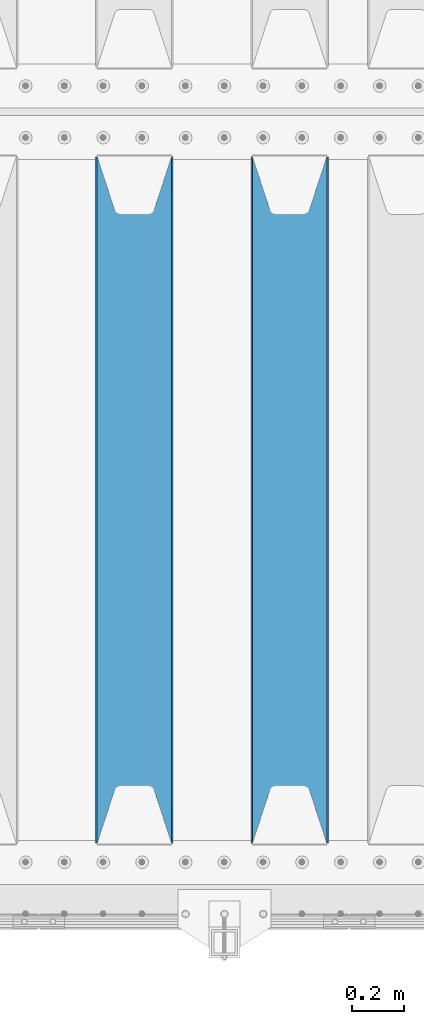
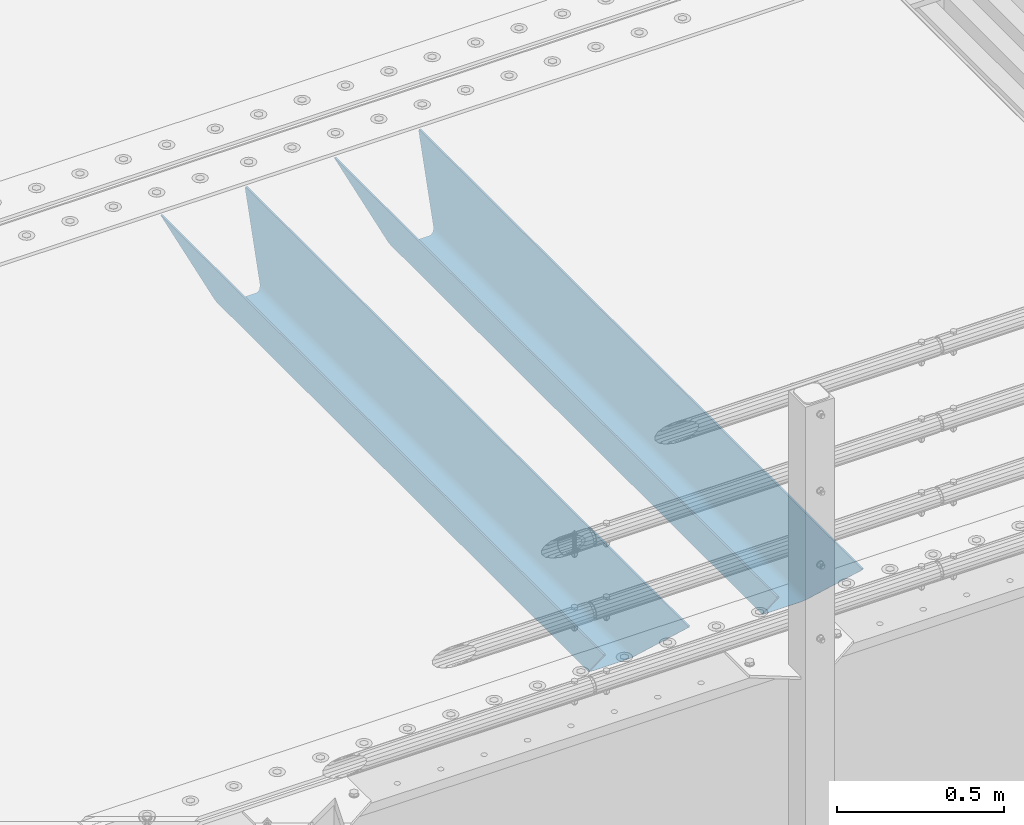
# One storey, part 130 of 242: 2 beams.
"""IFC2X3 building model written with IfcOpenShell, lengths in millimetres."""

from ifc_helpers import new_model, si_unit, frame, origin_with_axes, place, context, subcontext, project, spatial, faceted_brep, material, type_object, element, save


model = new_model("IFC2X3")

# Units and contexts
model_context = context("Model", 3, precision=1e-05, world=origin_with_axes())
body_context = subcontext(model_context, "Body", "Model", "MODEL_VIEW")
ifc_project = project(units=[si_unit("LENGTHUNIT", "METRE", prefix="MILLI"), si_unit("AREAUNIT", "SQUARE_METRE"), si_unit("VOLUMEUNIT", "CUBIC_METRE"), si_unit("MASSUNIT", "GRAM", prefix="KILO"), si_unit("TIMEUNIT", "SECOND"), si_unit("PLANEANGLEUNIT", "RADIAN"), si_unit("SOLIDANGLEUNIT", "STERADIAN"), si_unit("THERMODYNAMICTEMPERATUREUNIT", "DEGREE_CELSIUS"), si_unit("LUMINOUSINTENSITYUNIT", "LUMEN")], contexts=[model_context])

# Site, building, storey
site_placement = place(None, origin_with_axes())
site = spatial("IfcSite", under=ifc_project, at=site_placement, CompositionType="ELEMENT")
building_placement = place(site_placement, origin_with_axes())
building = spatial("IfcBuilding", under=site, at=building_placement, Name="Standard", CompositionType="ELEMENT")
storey_placement = place(building_placement, origin_with_axes())
storey = spatial("IfcBuildingStorey", under=building, at=storey_placement, Name="Undefined", CompositionType="ELEMENT", Elevation=0.0)

# Beams
ifc_material = material(Name="STEEL/S355N")
beam_type = type_object("IfcBeamType", PredefinedType="NOTDEFINED")
beam_1_placement = place(storey_placement, frame((-23780.0, -23825.0, -115.0), z_axis=(0.0, 0.0, 1.0), x_axis=(0.0, 1.0, 0.0)))
element("IfcBeam", 1, at=beam_1_placement, inside=storey, type_object=beam_type, material=ifc_material, context=body_context, shape_type="Brep", body=[
    faceted_brep([(0.0, 150.0, 115.0), (0.0, 143.689999999999, 115.0), (2650.00000000297, 143.689999999999, 115.0), (2650.00000000297, 150.0, 115.0), (2650.00000000297, 142.059565218402, 110.000000003099), (2650.00000000297, 148.369565218403, 110.000000003099), (2441.90079219209, -80.1103600731112, -98.0992078077845), (2437.7588105432, -77.5672621345584, -102.241189456673), (2434.06523489747, -74.4080125315522, -105.934765102404), (2430.91086095089, -70.710272125576, -109.089139048974), (2428.37322971128, -66.5649389910068, -111.626770288588), (2426.51472138055, -62.0739139532889, -113.485278619323), (2425.38102192092, -57.3475956567672, -114.618978078955), (2424.99999999987, -52.5021667386536, -115.0), (2424.99999999987, 52.5021667386536, -115.0), (2425.38102192092, 57.3475956567672, -114.618978078955), (2426.51472138055, 62.0739139532889, -113.485278619323), (2428.37322971128, 66.5649389910068, -111.626770288588), (2430.91086095089, 70.710272125576, -109.089139048974), (2434.06523489747, 74.4080125315522, -105.934765102404), (2437.7588105432, 77.5672621345584, -102.241189456673), (2441.90079219209, 80.1103600731112, -98.0992078077846), (2446.38936140511, 81.9747917625791, -93.6106385947584), (2448.2494850041, 76.2713538057251, -91.7505149957729), (2444.62967112262, 74.76777986261, -95.3703288772456), (2441.28936334126, 72.7168944282894, -98.710636658607), (2438.31067330438, 70.1691124903846, -101.689326695487), (2435.76682334747, 67.1870637758839, -104.233176652398), (2433.72034654133, 63.8440531834895, -106.279653458539), (2432.22154950042, 60.222258798236, -107.778450499454), (2431.30727574265, 56.4107117849089, -108.692724257221), (2430.99999999987, 52.5031078186876, -109.0), (2430.99999999987, -52.5031078186876, -109.0), (2431.30727574265, -56.4107117849089, -108.692724257221), (2432.22154950042, -60.222258798236, -107.778450499454), (2433.72034654133, -63.8440531834895, -106.279653458539), (2435.76682334747, -67.1870637758839, -104.233176652398), (2438.31067330438, -70.1691124903846, -101.689326695487), (2441.28936334126, -72.7168944282894, -98.7106366586071), (2444.62967112262, -74.76777986261, -95.3703288772457), (2448.2494850041, -76.2713538057251, -91.7505149957729), (2650.00000000297, -142.059565218402, 110.000000003099), (2650.00000000297, -148.369565218403, 110.000000003099), (2446.38936140511, -81.9747917625791, -93.6106385947584), (2650.00000000297, -143.689999999999, 115.0), (2650.00000000297, -150.0, 115.0), (0.0, -143.689999999999, 115.0), (0.0, -150.0, 115.0), (0.0, -148.369565218261, 110.000000002669), (203.610638597427, -81.9747917625791, -93.6106385947584), (208.099207810454, -80.1103600731112, -98.0992078077845), (212.241189459342, -77.5672621345584, -102.241189456673), (215.934765105074, -74.4080125315522, -105.934765102404), (219.089139051644, -70.710272125576, -109.089139048974), (221.626770291256, -66.5649389910068, -111.626770288588), (223.485278621993, -62.0739139532889, -113.485278619323), (224.618978081624, -57.3475956567672, -114.618978078955), (225.00000000267, -52.5021667386536, -115.0), (225.00000000267, 52.5021667386536, -115.0), (224.618978081624, 57.3475956567672, -114.618978078955), (223.485278621993, 62.0739139532889, -113.485278619323), (221.626770291256, 66.5649389910068, -111.626770288588), (219.089139051644, 70.710272125576, -109.089139048974), (215.934765105074, 74.4080125315522, -105.934765102404), (212.241189459342, 77.5672621345584, -102.241189456673), (208.099207810454, 80.1103600731112, -98.0992078077846), (203.610638597427, 81.9747917625791, -93.6106385947584), (0.0, 148.369565218261, 110.000000002669), (0.0, 142.05956521826, 110.000000002669), (201.750514998443, 76.2713538057251, -91.7505149957729), (205.370328879915, 74.76777986261, -95.3703288772456), (208.710636661275, 72.7168944282894, -98.710636658607), (211.689326698157, 70.1691124903846, -101.689326695487), (214.233176655067, 67.1870637758839, -104.233176652398), (216.279653461206, 63.8440531834895, -106.279653458539), (217.778450502123, 60.222258798236, -107.778450499454), (218.69272425989, 56.4107117849089, -108.692724257221), (219.00000000267, 52.5031078186876, -109.0), (219.00000000267, -52.5031078186876, -109.0), (218.69272425989, -56.4107117849089, -108.692724257221), (217.778450502123, -60.222258798236, -107.778450499454), (216.279653461206, -63.8440531834895, -106.279653458539), (214.233176655067, -67.1870637758839, -104.233176652398), (211.689326698157, -70.1691124903846, -101.689326695487), (208.710636661275, -72.7168944282894, -98.7106366586071), (205.370328879915, -74.76777986261, -95.3703288772457), (201.750514998443, -76.2713538057251, -91.7505149957729), (0.0, -142.05956521826, 110.000000002669)], [[[0, 1, 2, 3]], [[3, 2, 4, 5]], [[6, 7, 8, 9, 10, 11, 12, 13, 14, 15, 16, 17, 18, 19, 20, 21, 22, 5, 4, 23, 24, 25, 26, 27, 28, 29, 30, 31, 32, 33, 34, 35, 36, 37, 38, 39, 40, 41, 42, 43]], [[44, 45, 42, 41]], [[46, 47, 45, 44]], [[43, 42, 45, 47, 48, 49]], [[6, 43, 49, 50]], [[7, 6, 50, 51]], [[8, 7, 51, 52]], [[9, 8, 52, 53]], [[10, 9, 53, 54]], [[11, 10, 54, 55]], [[12, 11, 55, 56]], [[13, 12, 56, 57]], [[14, 13, 57, 58]], [[15, 14, 58, 59]], [[16, 15, 59, 60]], [[17, 16, 60, 61]], [[18, 17, 61, 62]], [[19, 18, 62, 63]], [[20, 19, 63, 64]], [[21, 20, 64, 65]], [[22, 21, 65, 66]], [[0, 3, 5, 22, 66, 67]], [[1, 0, 67, 68]], [[23, 4, 2, 1, 68, 69]], [[24, 23, 69, 70]], [[25, 24, 70, 71]], [[26, 25, 71, 72]], [[27, 26, 72, 73]], [[28, 27, 73, 74]], [[29, 28, 74, 75]], [[30, 29, 75, 76]], [[31, 30, 76, 77]], [[32, 31, 77, 78]], [[33, 32, 78, 79]], [[34, 33, 79, 80]], [[35, 34, 80, 81]], [[36, 35, 81, 82]], [[37, 36, 82, 83]], [[38, 37, 83, 84]], [[39, 38, 84, 85]], [[40, 39, 85, 86]], [[46, 44, 41, 40, 86, 87]], [[47, 46, 87, 48]], [[86, 85, 84, 83, 82, 81, 80, 79, 78, 77, 76, 75, 74, 73, 72, 71, 70, 69, 68, 67, 66, 65, 64, 63, 62, 61, 60, 59, 58, 57, 56, 55, 54, 53, 52, 51, 50, 49, 48, 87]]]),
])
beam_2_placement = place(storey_placement, frame((-24380.0, -23825.0, -115.0), z_axis=(0.0, 0.0, 1.0), x_axis=(0.0, 1.0, 0.0)))
element("IfcBeam", 2, at=beam_2_placement, inside=storey, type_object=beam_type, material=ifc_material, context=body_context, shape_type="Brep", body=[
    faceted_brep([(0.0, 150.0, 115.0), (0.0, 143.689999999999, 115.0), (2650.00000000297, 143.689999999999, 115.0), (2650.00000000297, 150.0, 115.0), (2650.00000000297, 142.059565218402, 110.000000003099), (2650.00000000297, 148.369565218403, 110.000000003099), (2441.90079219209, -80.1103600731112, -98.0992078077845), (2437.7588105432, -77.5672621345584, -102.241189456673), (2434.06523489747, -74.4080125315522, -105.934765102404), (2430.91086095089, -70.710272125576, -109.089139048974), (2428.37322971128, -66.5649389910068, -111.626770288588), (2426.51472138055, -62.0739139532889, -113.485278619323), (2425.38102192092, -57.3475956567672, -114.618978078955), (2424.99999999987, -52.5021667386536, -115.0), (2424.99999999987, 52.5021667386536, -115.0), (2425.38102192092, 57.3475956567672, -114.618978078955), (2426.51472138055, 62.0739139532889, -113.485278619323), (2428.37322971128, 66.5649389910068, -111.626770288588), (2430.91086095089, 70.710272125576, -109.089139048974), (2434.06523489747, 74.4080125315522, -105.934765102404), (2437.7588105432, 77.5672621345584, -102.241189456673), (2441.90079219209, 80.1103600731112, -98.0992078077846), (2446.38936140511, 81.9747917625791, -93.6106385947584), (2448.2494850041, 76.2713538057251, -91.7505149957729), (2444.62967112262, 74.76777986261, -95.3703288772456), (2441.28936334126, 72.7168944282894, -98.710636658607), (2438.31067330438, 70.1691124903846, -101.689326695487), (2435.76682334747, 67.1870637758839, -104.233176652398), (2433.72034654133, 63.8440531834895, -106.279653458539), (2432.22154950042, 60.222258798236, -107.778450499454), (2431.30727574265, 56.4107117849089, -108.692724257221), (2430.99999999987, 52.5031078186876, -109.0), (2430.99999999987, -52.5031078186876, -109.0), (2431.30727574265, -56.4107117849089, -108.692724257221), (2432.22154950042, -60.222258798236, -107.778450499454), (2433.72034654133, -63.8440531834895, -106.279653458539), (2435.76682334747, -67.1870637758839, -104.233176652398), (2438.31067330438, -70.1691124903846, -101.689326695487), (2441.28936334126, -72.7168944282894, -98.7106366586071), (2444.62967112262, -74.76777986261, -95.3703288772457), (2448.2494850041, -76.2713538057251, -91.7505149957729), (2650.00000000297, -142.059565218402, 110.000000003099), (2650.00000000297, -148.369565218403, 110.000000003099), (2446.38936140511, -81.9747917625791, -93.6106385947584), (2650.00000000297, -143.689999999999, 115.0), (2650.00000000297, -150.0, 115.0), (0.0, -143.689999999999, 115.0), (0.0, -150.0, 115.0), (0.0, -148.369565218261, 110.000000002669), (203.610638597427, -81.9747917625791, -93.6106385947584), (208.099207810454, -80.1103600731112, -98.0992078077845), (212.241189459342, -77.5672621345584, -102.241189456673), (215.934765105074, -74.4080125315522, -105.934765102404), (219.089139051644, -70.710272125576, -109.089139048974), (221.626770291256, -66.5649389910068, -111.626770288588), (223.485278621993, -62.0739139532889, -113.485278619323), (224.618978081624, -57.3475956567672, -114.618978078955), (225.00000000267, -52.5021667386536, -115.0), (225.00000000267, 52.5021667386536, -115.0), (224.618978081624, 57.3475956567672, -114.618978078955), (223.485278621993, 62.0739139532889, -113.485278619323), (221.626770291256, 66.5649389910068, -111.626770288588), (219.089139051644, 70.710272125576, -109.089139048974), (215.934765105074, 74.4080125315522, -105.934765102404), (212.241189459342, 77.5672621345584, -102.241189456673), (208.099207810454, 80.1103600731112, -98.0992078077846), (203.610638597427, 81.9747917625791, -93.6106385947584), (0.0, 148.369565218261, 110.000000002669), (0.0, 142.05956521826, 110.000000002669), (201.750514998443, 76.2713538057251, -91.7505149957729), (205.370328879915, 74.76777986261, -95.3703288772456), (208.710636661275, 72.7168944282894, -98.710636658607), (211.689326698157, 70.1691124903846, -101.689326695487), (214.233176655067, 67.1870637758839, -104.233176652398), (216.279653461206, 63.8440531834895, -106.279653458539), (217.778450502123, 60.222258798236, -107.778450499454), (218.69272425989, 56.4107117849089, -108.692724257221), (219.00000000267, 52.5031078186876, -109.0), (219.00000000267, -52.5031078186876, -109.0), (218.69272425989, -56.4107117849089, -108.692724257221), (217.778450502123, -60.222258798236, -107.778450499454), (216.279653461206, -63.8440531834895, -106.279653458539), (214.233176655067, -67.1870637758839, -104.233176652398), (211.689326698157, -70.1691124903846, -101.689326695487), (208.710636661275, -72.7168944282894, -98.7106366586071), (205.370328879915, -74.76777986261, -95.3703288772457), (201.750514998443, -76.2713538057251, -91.7505149957729), (0.0, -142.05956521826, 110.000000002669)], [[[0, 1, 2, 3]], [[3, 2, 4, 5]], [[6, 7, 8, 9, 10, 11, 12, 13, 14, 15, 16, 17, 18, 19, 20, 21, 22, 5, 4, 23, 24, 25, 26, 27, 28, 29, 30, 31, 32, 33, 34, 35, 36, 37, 38, 39, 40, 41, 42, 43]], [[44, 45, 42, 41]], [[46, 47, 45, 44]], [[43, 42, 45, 47, 48, 49]], [[6, 43, 49, 50]], [[7, 6, 50, 51]], [[8, 7, 51, 52]], [[9, 8, 52, 53]], [[10, 9, 53, 54]], [[11, 10, 54, 55]], [[12, 11, 55, 56]], [[13, 12, 56, 57]], [[14, 13, 57, 58]], [[15, 14, 58, 59]], [[16, 15, 59, 60]], [[17, 16, 60, 61]], [[18, 17, 61, 62]], [[19, 18, 62, 63]], [[20, 19, 63, 64]], [[21, 20, 64, 65]], [[22, 21, 65, 66]], [[0, 3, 5, 22, 66, 67]], [[1, 0, 67, 68]], [[23, 4, 2, 1, 68, 69]], [[24, 23, 69, 70]], [[25, 24, 70, 71]], [[26, 25, 71, 72]], [[27, 26, 72, 73]], [[28, 27, 73, 74]], [[29, 28, 74, 75]], [[30, 29, 75, 76]], [[31, 30, 76, 77]], [[32, 31, 77, 78]], [[33, 32, 78, 79]], [[34, 33, 79, 80]], [[35, 34, 80, 81]], [[36, 35, 81, 82]], [[37, 36, 82, 83]], [[38, 37, 83, 84]], [[39, 38, 84, 85]], [[40, 39, 85, 86]], [[46, 44, 41, 40, 86, 87]], [[47, 46, 87, 48]], [[86, 85, 84, 83, 82, 81, 80, 79, 78, 77, 76, 75, 74, 73, 72, 71, 70, 69, 68, 67, 66, 65, 64, 63, 62, 61, 60, 59, 58, 57, 56, 55, 54, 53, 52, 51, 50, 49, 48, 87]]]),
])

save(model, "model.ifc")
